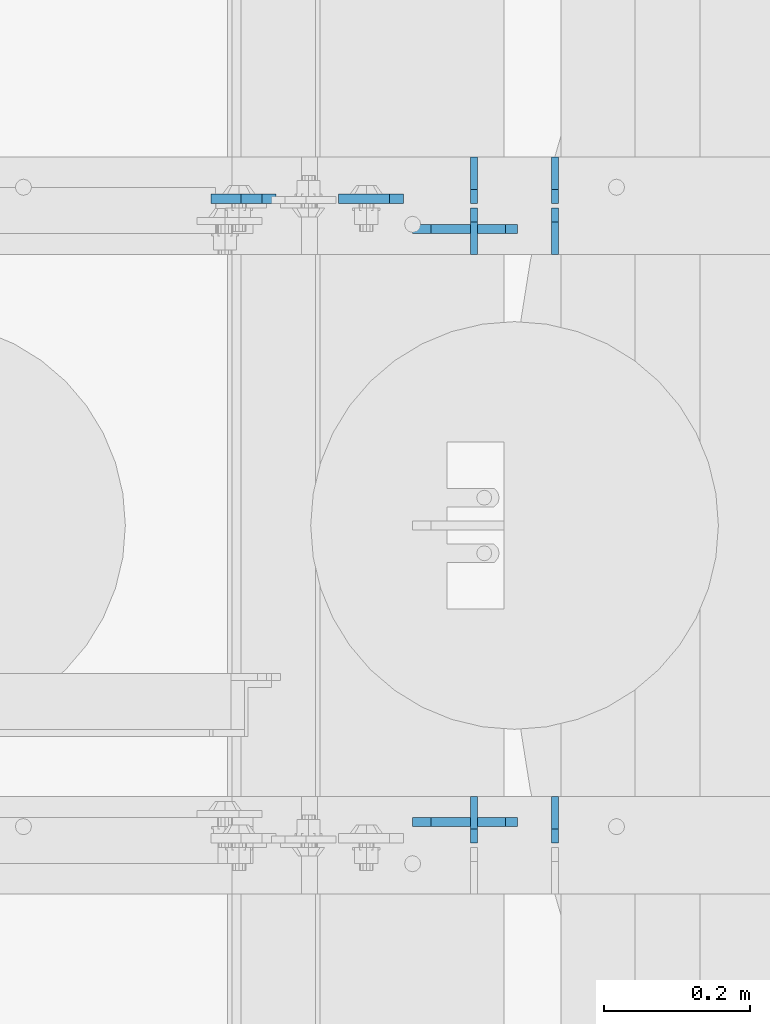
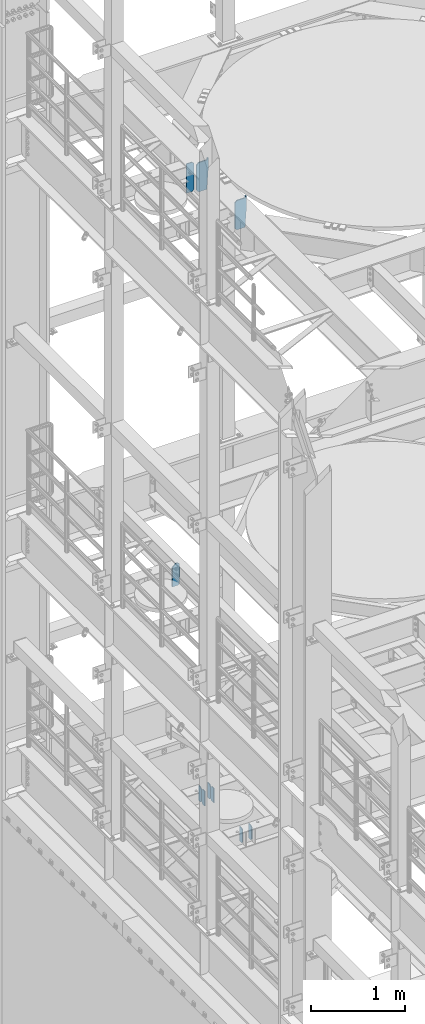
# One storey, part 1758 of 1876: 10 plates, 4 elements without a shape of their own.
"""IFC2X3 building model written with IfcOpenShell, lengths in millimetres."""

from ifc_helpers import new_model, si_unit, frame, origin_with_axes, place, context, subcontext, project, spatial, faceted_brep, material, type_object, element, aggregate, save


model = new_model("IFC2X3")

# Units and contexts
model_context = context("Model", 3, precision=1e-05, world=origin_with_axes())
body_context = subcontext(model_context, "Body", "Model", "MODEL_VIEW")
ifc_project = project(units=[si_unit("LENGTHUNIT", "METRE", prefix="MILLI"), si_unit("AREAUNIT", "SQUARE_METRE"), si_unit("VOLUMEUNIT", "CUBIC_METRE"), si_unit("MASSUNIT", "GRAM", prefix="KILO"), si_unit("TIMEUNIT", "SECOND"), si_unit("PLANEANGLEUNIT", "RADIAN"), si_unit("SOLIDANGLEUNIT", "STERADIAN"), si_unit("THERMODYNAMICTEMPERATUREUNIT", "DEGREE_CELSIUS"), si_unit("LUMINOUSINTENSITYUNIT", "LUMEN")], contexts=[model_context])

# Site, building, storey
site_placement = place(None, origin_with_axes())
site = spatial("IfcSite", under=ifc_project, at=site_placement, CompositionType="ELEMENT")
building_placement = place(site_placement, origin_with_axes())
building = spatial("IfcBuilding", under=site, at=building_placement, Name="Undefined", CompositionType="ELEMENT")
storey_placement = place(building_placement, origin_with_axes())
storey = spatial("IfcBuildingStorey", under=building, at=storey_placement, Name="Undefined", CompositionType="ELEMENT", Elevation=0.0)

# Assembly, plates
assembly_1_placement = place(storey_placement, origin_with_axes())
assembly_1 = element("IfcElementAssembly", 1, at=assembly_1_placement, inside=storey, Name="BEAM", AssemblyPlace="NOTDEFINED", PredefinedType="RIGID_FRAME")
ifc_material = material(Name="STEEL/A36")
plate_type_1 = type_object("IfcPlateType", PredefinedType="NOTDEFINED")
plate_1_placement = place(assembly_1_placement, frame((1325.5625, 11985.625, 5122.8625), z_axis=(0.0, 0.0, -1.0), x_axis=(0.0, -1.0, 0.0)))
plate_1 = element("IfcPlate", 2, at=plate_1_placement, type_object=plate_type_1, material=ifc_material, Name="PLATE", context=body_context, shape_type="Brep", body=[
    faceted_brep([(0.0, -4.76249999999982, 0.0), (0.0, -4.76249999999982, 190.5), (0.0, 4.76249999999982, 190.5), (0.0, 4.76249999999982, 0.0), (44.4500007629395, -4.76249999999982, 190.5), (44.4500007629395, 4.76249999999982, 190.5), (63.5, -4.76249999999982, 171.450000762939), (63.5, 4.76249999999982, 171.450000762939), (63.5, -4.76249999999982, 19.0499992370605), (63.5, 4.76249999999982, 19.0499992370605), (44.4500007629395, -4.76249999999982, 0.0), (44.4500007629395, 4.76249999999982, 0.0)], [[[0, 1, 2, 3]], [[1, 4, 5, 2]], [[4, 6, 7, 5]], [[6, 8, 9, 7]], [[8, 10, 11, 9]], [[10, 0, 3, 11]], [[5, 7, 9, 11, 3, 2]], [[10, 8, 6, 4, 1, 0]]]),
])
plate_2_placement = place(assembly_1_placement, frame((1214.4375, 11985.625, 5122.8625), z_axis=(0.0, 0.0, -1.0), x_axis=(0.0, -1.0, 0.0)))
plate_2 = element("IfcPlate", 3, at=plate_2_placement, type_object=plate_type_1, material=ifc_material, Name="PLATE", context=body_context, shape_type="Brep", body=[
    faceted_brep([(0.0, -4.76249999999982, 0.0), (0.0, -4.76249999999982, 190.5), (0.0, 4.76249999999982, 190.5), (0.0, 4.76249999999982, 0.0), (44.4500007629395, -4.76249999999982, 190.5), (44.4500007629395, 4.76249999999982, 190.5), (63.5, -4.76249999999982, 171.450000762939), (63.5, 4.76249999999982, 171.450000762939), (63.5, -4.76249999999982, 19.0499992370605), (63.5, 4.76249999999982, 19.0499992370605), (44.4500007629395, -4.76249999999982, 0.0), (44.4500007629395, 4.76249999999982, 0.0)], [[[0, 1, 2, 3]], [[1, 4, 5, 2]], [[4, 6, 7, 5]], [[6, 8, 9, 7]], [[8, 10, 11, 9]], [[10, 0, 3, 11]], [[5, 7, 9, 11, 3, 2]], [[10, 8, 6, 4, 1, 0]]]),
])

assembly_2_placement = place(storey_placement, origin_with_axes())
assembly_2 = element("IfcElementAssembly", 4, at=assembly_2_placement, inside=storey, Name="BEAM", AssemblyPlace="NOTDEFINED", PredefinedType="RIGID_FRAME")
plate_3_placement = place(assembly_2_placement, frame((1325.5625, 11045.825, 4932.3625), z_axis=(0.0, 0.0, 1.0), x_axis=(0.0, 1.0, 0.0)))
plate_3 = element("IfcPlate", 5, at=plate_3_placement, type_object=plate_type_1, material=ifc_material, Name="PLATE", context=body_context, shape_type="Brep", body=[
    faceted_brep([(0.0, -4.76249999999982, 19.0499992370605), (0.0, -4.76249999999982, 171.450000762939), (0.0, 4.76249999999982, 171.450000762939), (0.0, 4.76249999999982, 19.0499992370605), (19.0499992370605, -4.76249999999982, 190.5), (19.0499992370605, 4.76249999999982, 190.5), (63.5, -4.76249999999982, 190.5), (63.5, 4.76249999999982, 190.5), (63.5, -4.76249999999982, 0.0), (63.5, 4.76249999999982, 0.0), (19.0499992370605, -4.76249999999982, 0.0), (19.0499992370605, 4.76249999999982, 0.0)], [[[0, 1, 2, 3]], [[1, 4, 5, 2]], [[4, 6, 7, 5]], [[6, 8, 9, 7]], [[8, 10, 11, 9]], [[10, 0, 3, 11]], [[5, 7, 9, 11, 3, 2]], [[10, 8, 6, 4, 1, 0]]]),
])
plate_4_placement = place(assembly_2_placement, frame((1214.4375, 11045.825, 4932.3625), z_axis=(0.0, 0.0, 1.0), x_axis=(0.0, 1.0, 0.0)))
plate_4 = element("IfcPlate", 6, at=plate_4_placement, type_object=plate_type_1, material=ifc_material, Name="PLATE", context=body_context, shape_type="Brep", body=[
    faceted_brep([(0.0, -4.76249999999982, 19.0499992370605), (0.0, -4.76249999999982, 171.450000762939), (0.0, 4.76249999999982, 171.450000762939), (0.0, 4.76249999999982, 19.0499992370605), (19.0499992370605, -4.76249999999982, 190.5), (19.0499992370605, 4.76249999999982, 190.5), (63.5, -4.76249999999982, 190.5), (63.5, 4.76249999999982, 190.5), (63.5, -4.76249999999982, 0.0), (63.5, 4.76249999999982, 0.0), (19.0499992370605, -4.76249999999982, 0.0), (19.0499992370605, 4.76249999999982, 0.0)], [[[0, 1, 2, 3]], [[1, 4, 5, 2]], [[4, 6, 7, 5]], [[6, 8, 9, 7]], [[8, 10, 11, 9]], [[10, 0, 3, 11]], [[5, 7, 9, 11, 3, 2]], [[10, 8, 6, 4, 1, 0]]]),
])
aggregate(assembly_2, [plate_3, plate_4])

# Plate
plate_5_placement = place(assembly_1_placement, frame((1325.5625, 11915.775, 5122.8625), z_axis=(0.0, 0.0, -1.0), x_axis=(0.0, -1.0, 0.0)))
plate_5 = element("IfcPlate", 7, at=plate_5_placement, type_object=plate_type_1, material=ifc_material, Name="PLATE", context=body_context, shape_type="Brep", body=[
    faceted_brep([(0.0, -4.76249999999982, 19.0499992370605), (0.0, -4.76249999999982, 171.450000762939), (0.0, 4.76249999999982, 171.450000762939), (0.0, 4.76249999999982, 19.0499992370605), (19.0499992370605, -4.76249999999982, 190.5), (19.0499992370605, 4.76249999999982, 190.5), (63.5, -4.76249999999982, 190.5), (63.5, 4.76249999999982, 190.5), (63.5, -4.76249999999982, 0.0), (63.5, 4.76249999999982, 0.0), (19.0499992370605, -4.76249999999982, 0.0), (19.0499992370605, 4.76249999999982, 0.0)], [[[0, 1, 2, 3]], [[1, 4, 5, 2]], [[4, 6, 7, 5]], [[6, 8, 9, 7]], [[8, 10, 11, 9]], [[10, 0, 3, 11]], [[5, 7, 9, 11, 3, 2]], [[10, 8, 6, 4, 1, 0]]]),
])

plate_6_placement = place(assembly_1_placement, frame((1214.4375, 11915.775, 5122.8625), z_axis=(0.0, 0.0, -1.0), x_axis=(0.0, -1.0, 0.0)))
plate_6 = element("IfcPlate", 8, at=plate_6_placement, type_object=plate_type_1, material=ifc_material, Name="PLATE", context=body_context, shape_type="Brep", body=[
    faceted_brep([(0.0, -4.76249999999982, 19.0499992370605), (0.0, -4.76249999999982, 171.450000762939), (0.0, 4.76249999999982, 171.450000762939), (0.0, 4.76249999999982, 19.0499992370605), (19.0499992370605, -4.76249999999982, 190.5), (19.0499992370605, 4.76249999999982, 190.5), (63.5, -4.76249999999982, 190.5), (63.5, 4.76249999999982, 190.5), (63.5, -4.76249999999982, 0.0), (63.5, 4.76249999999982, 0.0), (19.0499992370605, -4.76249999999982, 0.0), (19.0499992370605, 4.76249999999982, 0.0)], [[[0, 1, 2, 3]], [[1, 4, 5, 2]], [[4, 6, 7, 5]], [[6, 8, 9, 7]], [[8, 10, 11, 9]], [[10, 0, 3, 11]], [[5, 7, 9, 11, 3, 2]], [[10, 8, 6, 4, 1, 0]]]),
])

aggregate(assembly_1, [plate_1, plate_2, plate_5, plate_6])

# Assembly, plate
assembly_3_placement = place(storey_placement, origin_with_axes())
assembly_3 = element("IfcElementAssembly", 9, at=assembly_3_placement, inside=storey, Name="BEAM", AssemblyPlace="NOTDEFINED", PredefinedType="RIGID_FRAME")
plate_type_2 = type_object("IfcPlateType", PredefinedType="NOTDEFINED")
plate_7_placement = place(assembly_3_placement, frame((1117.60000480063, 11928.475, 12907.9625), z_axis=(0.0, 0.0, 1.0), x_axis=(-1.0, 0.0, 0.0)))
plate_7 = element("IfcPlate", 10, at=plate_7_placement, type_object=plate_type_2, material=ifc_material, Name="PLATE", context=body_context, shape_type="Brep", body=[
    faceted_brep([(0.0, -6.35000000000196, 19.0499992370605), (0.0, -6.35000000000036, 360.362506866455), (0.0, 6.35000000000036, 360.362506866455), (0.0, 6.35000000000105, 19.0499992370605), (19.0499992370605, -6.35000000000036, 379.412506103516), (19.0499992370605, 6.35000000000036, 379.412506103516), (88.9000015258789, -6.35000000000036, 379.412506103516), (88.9000015258789, 6.35000000000036, 379.412506103516), (88.9000015258789, -6.34999999999991, 0.0), (88.9000015258789, 6.34999999999991, 0.0), (19.0499992370642, -6.35000000000105, 0.0), (19.0499992370633, 6.35000000000105, 0.0)], [[[0, 1, 2, 3]], [[1, 4, 5, 2]], [[4, 6, 7, 5]], [[6, 8, 9, 7]], [[8, 10, 11, 9]], [[10, 0, 3, 11]], [[5, 7, 9, 11, 3, 2]], [[10, 8, 6, 4, 1, 0]]]),
])

assembly_4_placement = place(storey_placement, origin_with_axes())
assembly_4 = element("IfcElementAssembly", 11, at=assembly_4_placement, inside=storey, Name="BEAM", AssemblyPlace="NOTDEFINED", PredefinedType="RIGID_FRAME")
plate_8_placement = place(assembly_4_placement, frame((942.975, 11928.475, 7856.5375), z_axis=(0.0, 0.0, 1.0), x_axis=(-1.0, 0.0, 0.0)))
plate_8 = element("IfcPlate", 12, at=plate_8_placement, type_object=plate_type_2, material=ifc_material, Name="PLATE", context=body_context, shape_type="Brep", body=[
    faceted_brep([(0.0, -6.35000000000036, 271.462512969971), (19.0499992370605, -6.35000000000036, 290.512512207031), (19.0499992370605, 6.35000000000036, 290.512512207031), (0.0, 6.35000000000036, 271.462512969971), (0.0, -6.35000000000196, 19.0499992370605), (0.0, 6.35000000000105, 19.0499992370605), (19.0499992370642, -6.35000000000105, 0.0), (19.0499992370633, 6.35000000000105, 0.0), (88.9000015258789, -6.34999999999991, 0.0), (88.9000015258789, 6.34999999999991, 0.0), (88.9000015258789, -6.35000000000036, 249.237510681152), (47.625, -6.35000000000036, 290.512512207031), (47.625, 6.35000000000036, 290.512512207031), (88.9000015258789, 6.35000000000036, 249.237510681152)], [[[0, 1, 2, 3]], [[4, 0, 3, 5]], [[6, 4, 5, 7]], [[8, 6, 7, 9]], [[6, 8, 10, 11, 1, 0, 4]], [[1, 11, 12, 2]], [[2, 12, 13, 9, 7, 5, 3]], [[10, 8, 9, 13]], [[11, 10, 13, 12]]]),
])
aggregate(assembly_4, [plate_8])

# Plate
plate_type_3 = type_object("IfcPlateType", PredefinedType="NOTDEFINED")
plate_9_placement = place(assembly_3_placement, frame((1255.71250327475, 11887.2, 12906.375), z_axis=(0.0, 0.0, 1.0), x_axis=(-1.0, 0.0, 0.0)))
plate_9 = element("IfcPlate", 13, at=plate_9_placement, type_object=plate_type_3, material=ifc_material, Name="PLATE", context=body_context, shape_type="Brep", body=[
    faceted_brep([(0.0, -6.35000000000036, 0.0), (-18.2513217926025, -6.35000000000036, 276.225006103516), (-18.2513217926025, 6.35000000000036, 276.225006103516), (0.0, 6.35000000000036, 0.0), (-18.2517261505127, -6.35000000000036, 403.225006103516), (-18.2517261505127, 6.35000000000036, 403.225006103516), (-1.58749985694885, -6.35000000000036, 403.225006103516), (-1.58749985694885, 6.35000000000036, 403.225006103516), (-1.58775019645691, -6.35000000000036, 380.999969482422), (-1.58775019645691, 6.35000000000036, 380.999969482422), (100.012498855591, -6.35000000000036, 381.0), (100.012498855591, 6.35000000000036, 381.0), (125.412498474121, -6.35000000000036, 355.60000038147), (125.412498474121, 6.35000000000036, 355.60000038147), (125.412498474121, -6.35000000000036, 25.3999996185303), (125.412498474121, 6.35000000000036, 25.3999996185303), (100.012498855591, -6.35000000000036, 0.0), (100.012498855591, 6.35000000000036, 0.0)], [[[0, 1, 2, 3]], [[1, 4, 5, 2]], [[4, 6, 7, 5]], [[6, 8, 9, 7]], [[8, 10, 11, 9]], [[10, 12, 13, 11]], [[12, 14, 15, 13]], [[14, 16, 17, 15]], [[16, 0, 3, 17]], [[5, 7, 9, 11, 13, 15, 17, 3, 2]], [[16, 14, 12, 10, 8, 6, 4, 1, 0]]]),
])

plate_10_placement = place(assembly_3_placement, frame((1255.71250327475, 11074.4, 12906.375), z_axis=(0.0, 0.0, 1.0), x_axis=(-1.0, 0.0, 0.0)))
plate_10 = element("IfcPlate", 14, at=plate_10_placement, type_object=plate_type_3, material=ifc_material, Name="PLATE", context=body_context, shape_type="Brep", body=[
    faceted_brep([(0.0, -6.35000000000036, 0.0), (-18.1444339752197, -6.35000000000036, 276.225006103516), (-18.1444339752197, 6.35000000000036, 276.225006103516), (0.0, 6.35000000000036, 0.0), (-18.1448383331299, -6.35000000000036, 403.225006103516), (-18.1448383331299, 6.35000000000036, 403.225006103516), (-1.58749985694885, -6.35000000000036, 403.225006103516), (-1.58749985694885, 6.35000000000036, 403.225006103516), (-1.58775019645691, -6.35000000000036, 380.999969482422), (-1.58775019645691, 6.35000000000036, 380.999969482422), (100.012498855591, -6.35000000000036, 381.0), (100.012498855591, 6.35000000000036, 381.0), (125.412498474121, -6.35000000000036, 355.60000038147), (125.412498474121, 6.35000000000036, 355.60000038147), (125.412498474121, -6.35000000000036, 25.3999996185303), (125.412498474121, 6.35000000000036, 25.3999996185303), (100.012498855591, -6.35000000000036, 0.0), (100.012498855591, 6.35000000000036, 0.0)], [[[0, 1, 2, 3]], [[1, 4, 5, 2]], [[4, 6, 7, 5]], [[6, 8, 9, 7]], [[8, 10, 11, 9]], [[10, 12, 13, 11]], [[12, 14, 15, 13]], [[14, 16, 17, 15]], [[16, 0, 3, 17]], [[5, 7, 9, 11, 13, 15, 17, 3, 2]], [[16, 14, 12, 10, 8, 6, 4, 1, 0]]]),
])

aggregate(assembly_3, [plate_9, plate_10, plate_7])

save(model, "model.ifc")
